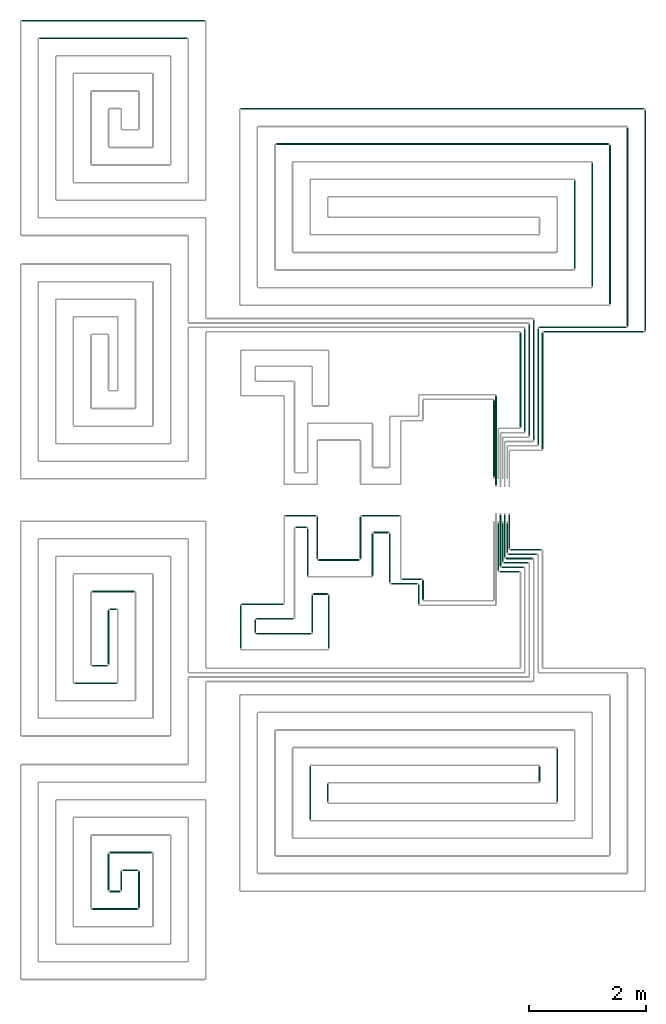
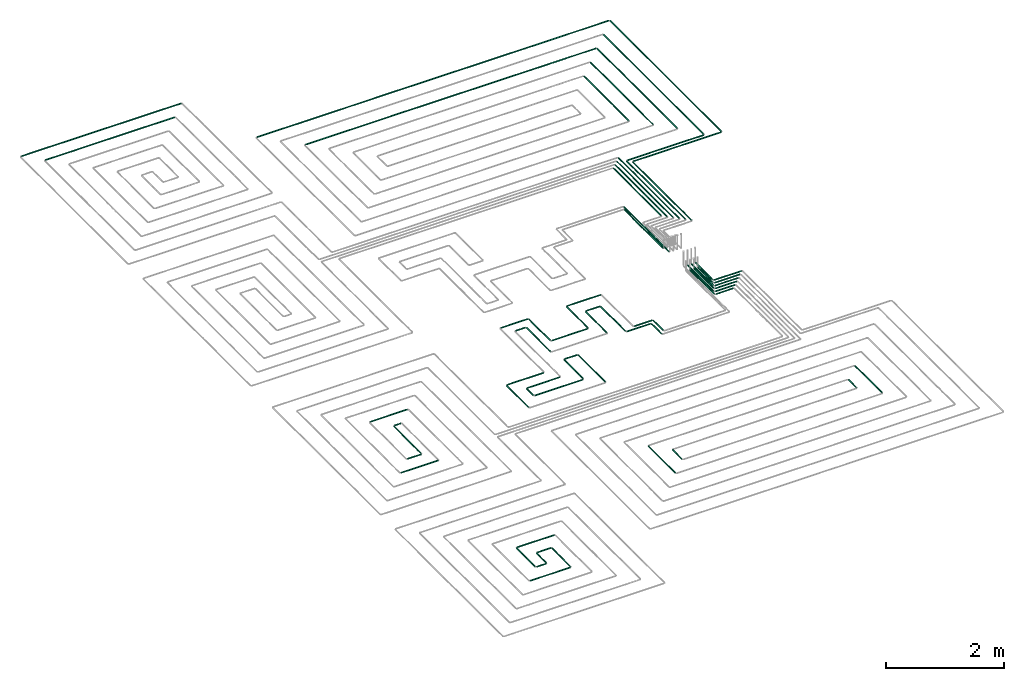
# One storey, part 3 of 12: 69 flow segments.
"""IFC2X3 building model written with IfcOpenShell, lengths in millimetres."""

from ifc_helpers import new_model, entity, si_unit, converted_unit, derived_unit, direction, frame, frame_2d, origin, origin_2d_with_axis, place, context, subcontext, project, spatial, circle, extrude, type_object, element, save


model = new_model("IFC2X3")

# Units and contexts
model_context = context("Model", 3, precision=0.01, world=origin(), true_north=direction((6.12303176911189e-17, 1.0)))
body_context = subcontext(model_context, "Body", "Model", "MODEL_VIEW")
ifc_project = project(units=[si_unit("LENGTHUNIT", "METRE", prefix="MILLI"), si_unit("AREAUNIT", "SQUARE_METRE"), si_unit("VOLUMEUNIT", "CUBIC_METRE"), converted_unit("PLANEANGLEUNIT", "DEGREE", entity("IfcRatioMeasure", 0.0174532925199433), si_unit("PLANEANGLEUNIT", "RADIAN"), dimensions=[0, 0, 0, 0, 0, 0, 0]), si_unit("MASSUNIT", "GRAM", prefix="KILO"), derived_unit("MASSDENSITYUNIT", [(si_unit("MASSUNIT", "GRAM", prefix="KILO"), 1), (si_unit("LENGTHUNIT", "METRE"), -3)]), si_unit("TIMEUNIT", "SECOND"), si_unit("FREQUENCYUNIT", "HERTZ"), si_unit("THERMODYNAMICTEMPERATUREUNIT", "DEGREE_CELSIUS"), derived_unit("THERMALTRANSMITTANCEUNIT", [(si_unit("MASSUNIT", "GRAM", prefix="KILO"), 1), (si_unit("THERMODYNAMICTEMPERATUREUNIT", "KELVIN"), -1), (si_unit("TIMEUNIT", "SECOND"), -3)]), derived_unit("VOLUMETRICFLOWRATEUNIT", [(si_unit("LENGTHUNIT", "METRE"), 3), (si_unit("TIMEUNIT", "SECOND"), -1)]), si_unit("ELECTRICCURRENTUNIT", "AMPERE"), si_unit("ELECTRICVOLTAGEUNIT", "VOLT"), si_unit("POWERUNIT", "WATT"), si_unit("FORCEUNIT", "NEWTON", prefix="KILO"), si_unit("ILLUMINANCEUNIT", "LUX"), si_unit("LUMINOUSFLUXUNIT", "LUMEN"), si_unit("LUMINOUSINTENSITYUNIT", "CANDELA"), derived_unit("USERDEFINED", [(si_unit("MASSUNIT", "GRAM", prefix="KILO"), -1), (si_unit("LENGTHUNIT", "METRE"), -2), (si_unit("TIMEUNIT", "SECOND"), 3), (si_unit("LUMINOUSFLUXUNIT", "LUMEN"), 1)]), derived_unit("LINEARVELOCITYUNIT", [(si_unit("LENGTHUNIT", "METRE"), 1), (si_unit("TIMEUNIT", "SECOND"), -1)]), si_unit("PRESSUREUNIT", "PASCAL"), derived_unit("USERDEFINED", [(si_unit("LENGTHUNIT", "METRE"), -2), (si_unit("MASSUNIT", "GRAM", prefix="KILO"), 1), (si_unit("TIMEUNIT", "SECOND"), -2)])], contexts=[model_context])

# Site, building, storey
site_placement = place(None, origin())
site = spatial("IfcSite", under=ifc_project, at=site_placement, CompositionType="ELEMENT")
building_placement = place(site_placement, origin())
building = spatial("IfcBuilding", under=site, at=building_placement, CompositionType="ELEMENT")
storey_placement = place(building_placement, frame((0.0, 0.0, 8000.0)))
storey = spatial("IfcBuildingStorey", under=building, at=storey_placement, Name="02 Level", CompositionType="ELEMENT", Elevation=8000.0)

# Flow segments
pipe_segment_type = type_object("IfcPipeSegmentType", PredefinedType="NOTDEFINED")
flow_segment_1_placement = place(storey_placement, frame((24021.0090559391, -70269.05691443, -81.5952722359243)))
element("IfcFlowSegment", 1, at=flow_segment_1_placement, inside=storey, type_object=pipe_segment_type, context=body_context, shape_type="SweptSolid", body=[
    extrude(circle(Radius=10.0, at=frame_2d((8.66293703438714e-12, 0.0), x_axis=(1.0, 0.0))), frame((0.0, 11.5952722359136, 11.5952722359158), z_axis=(1.0, 0.0, 0.0), x_axis=(0.0, 1.0, 0.0)), (0.0, 0.0, 1.0), 450.721832403925),
])
flow_segment_2_placement = place(storey_placement, frame((18625.6253473194, -71966.1931086591, -81.5952722359225)))
element("IfcFlowSegment", 2, at=flow_segment_2_placement, inside=storey, type_object=pipe_segment_type, context=body_context, shape_type="SweptSolid", body=[
    extrude(circle(Radius=10.0, at=origin_2d_with_axis()), frame((0.0, 11.5952722359136, 11.5952722359158), z_axis=(1.0, 0.0, 0.0), x_axis=(0.0, 1.0, 0.0)), (0.0, 0.0, 1.0), 718.813282054726),
])
flow_segment_3_placement = place(storey_placement, frame((18925.6253473194, -70402.8348573758, -81.5952722359234)))
element("IfcFlowSegment", 3, at=flow_segment_3_placement, inside=storey, type_object=pipe_segment_type, context=body_context, shape_type="SweptSolid", body=[
    extrude(circle(Radius=10.0, at=origin_2d_with_axis()), frame((0.0, 11.5952722359136, 11.5952722359158), z_axis=(1.0, 0.0, 0.0), x_axis=(0.0, -1.0, 0.0)), (0.0, 0.0, 1.0), 718.813282054721),
])
flow_segment_4_placement = place(storey_placement, frame((19225.6253473194, -70702.8348573758, -81.5952722359225)))
element("IfcFlowSegment", 4, at=flow_segment_4_placement, inside=storey, type_object=pipe_segment_type, context=body_context, shape_type="SweptSolid", body=[
    extrude(circle(Radius=10.0, at=frame_2d((-8.66293703438714e-12, 0.0), x_axis=(1.0, 0.0))), frame((0.0, 11.5952722359136, 11.5952722359158), z_axis=(1.0, 0.0, 0.0), x_axis=(0.0, 1.0, 0.0)), (0.0, 0.0, 1.0), 118.813282054734),
])
flow_segment_5_placement = place(storey_placement, frame((19194.0300750835, -71634.5978364232, -81.5952722359234)))
element("IfcFlowSegment", 5, at=flow_segment_5_placement, inside=storey, type_object=pipe_segment_type, context=body_context, shape_type="SweptSolid", body=[
    extrude(circle(Radius=10.0, at=frame_2d((-2.16573425859679e-12, 0.0), x_axis=(1.0, 0.0))), frame((11.595272235918, 0.0, 11.5952722359158), z_axis=(0.0, 1.0, 0.0), x_axis=(-1.0, 0.0, 0.0)), (0.0, 0.0, 1.0), 923.358251283313),
])
flow_segment_6_placement = place(storey_placement, frame((18925.6253473194, -71666.1931086591, -81.5952722359252)))
element("IfcFlowSegment", 6, at=flow_segment_6_placement, inside=storey, type_object=pipe_segment_type, context=body_context, shape_type="SweptSolid", body=[
    extrude(circle(Radius=10.0, at=frame_2d((8.66293703438714e-12, 0.0), x_axis=(1.0, 0.0))), frame((0.0, 11.5952722359136, 11.5952722359158), z_axis=(1.0, 0.0, 0.0), x_axis=(0.0, 1.0, 0.0)), (0.0, 0.0, 1.0), 260.000000000012),
])
flow_segment_7_placement = place(storey_placement, frame((19712.8433571382, -75784.5978364232, -81.5952722359252)))
element("IfcFlowSegment", 7, at=flow_segment_7_placement, inside=storey, type_object=pipe_segment_type, context=body_context, shape_type="SweptSolid", body=[
    extrude(circle(Radius=10.0, at=frame_2d((-8.66293703438714e-12, 0.0), x_axis=(1.0, 0.0))), frame((11.5952722359266, 0.0, 11.5952722359158), z_axis=(0.0, 1.0, 0.0), x_axis=(-1.0, 0.0, 0.0)), (0.0, 0.0, 1.0), 623.358251283277),
])
flow_segment_8_placement = place(storey_placement, frame((19412.8433571382, -75484.5978364232, -81.595272235927)))
element("IfcFlowSegment", 8, at=flow_segment_8_placement, inside=storey, type_object=pipe_segment_type, context=body_context, shape_type="SweptSolid", body=[
    extrude(circle(Radius=10.0, at=frame_2d((6.49720277579036e-12, 0.0), x_axis=(1.0, 0.0))), frame((11.5952722359223, 0.0, 11.5952722359158), z_axis=(0.0, 1.0, 0.0), x_axis=(-1.0, 0.0, 0.0)), (0.0, 0.0, 1.0), 323.358251283363),
])
flow_segment_9_placement = place(storey_placement, frame((19194.0300750835, -75484.5978364232, -81.5952722359252)))
element("IfcFlowSegment", 9, at=flow_segment_9_placement, inside=storey, type_object=pipe_segment_type, context=body_context, shape_type="SweptSolid", body=[
    extrude(circle(Radius=10.0, at=frame_2d((-6.49720277579036e-12, 0.0), x_axis=(1.0, 0.0))), frame((11.5952722359223, 0.0, 11.5952722359158), z_axis=(0.0, 1.0, 0.0), x_axis=(-1.0, 0.0, 0.0)), (0.0, 0.0, 1.0), 623.358251283355),
])
flow_segment_10_placement = place(storey_placement, frame((19225.6253473194, -74852.8348573758, -81.5952722359198)))
element("IfcFlowSegment", 10, at=flow_segment_10_placement, inside=storey, type_object=pipe_segment_type, context=body_context, shape_type="SweptSolid", body=[
    extrude(circle(Radius=10.0, at=frame_2d((-2.59888111031614e-11, 0.0), x_axis=(1.0, 0.0))), frame((0.0, 11.5952722359396, 11.5952722359158), z_axis=(1.0, 0.0, 0.0), x_axis=(0.0, 1.0, 0.0)), (0.0, 0.0, 1.0), 718.813282054736),
])
flow_segment_11_placement = place(storey_placement, frame((18925.6253473194, -75816.1931086591, -81.5952722359243)))
element("IfcFlowSegment", 11, at=flow_segment_11_placement, inside=storey, type_object=pipe_segment_type, context=body_context, shape_type="SweptSolid", body=[
    extrude(circle(Radius=10.0, at=frame_2d((3.46517481375486e-11, 0.0), x_axis=(1.0, 0.0))), frame((0.0, 11.595272235931, 11.5952722359158), z_axis=(1.0, 0.0, 0.0), x_axis=(0.0, 1.0, 0.0)), (0.0, 0.0, 1.0), 778.813282054757),
])
flow_segment_12_placement = place(storey_placement, frame((19225.6253473194, -75516.1931086591, -81.5952722359252)))
element("IfcFlowSegment", 12, at=flow_segment_12_placement, inside=storey, type_object=pipe_segment_type, context=body_context, shape_type="SweptSolid", body=[
    extrude(circle(Radius=10.0, at=origin_2d_with_axis()), frame((0.0, 11.5952722359136, 11.5952722359158), z_axis=(1.0, 0.0, 0.0), x_axis=(0.0, 1.0, 0.0)), (0.0, 0.0, 1.0), 178.813282054764),
])
flow_segment_13_placement = place(storey_placement, frame((19444.4386293741, -75152.8348573758, -81.5952722359243)))
element("IfcFlowSegment", 13, at=flow_segment_13_placement, inside=storey, type_object=pipe_segment_type, context=body_context, shape_type="SweptSolid", body=[
    extrude(circle(Radius=10.0, at=frame_2d((-8.66293703438714e-12, 0.0), x_axis=(1.0, 0.0))), frame((0.0, 11.595272235931, 11.5952722359158), z_axis=(1.0, 0.0, 0.0), x_axis=(0.0, 1.0, 0.0)), (0.0, 0.0, 1.0), 260.000000000017),
])
flow_segment_14_placement = place(storey_placement, frame((26841.5018091839, -73979.8436457933, -81.5952722359198)))
element("IfcFlowSegment", 14, at=flow_segment_14_placement, inside=storey, type_object=pipe_segment_type, context=body_context, shape_type="SweptSolid", body=[
    extrude(circle(Radius=10.0, at=frame_2d((-8.66293703438714e-12, 0.0), x_axis=(1.0, 0.0))), frame((11.5952722359266, 0.0, 11.5952722359158), z_axis=(0.0, 1.0, 0.0), x_axis=(-1.0, 0.0, 0.0)), (0.0, 0.0, 1.0), 907.858932130948),
])
flow_segment_15_placement = place(storey_placement, frame((22930.6562350406, -73979.8436457933, -81.5952722359307)))
element("IfcFlowSegment", 15, at=flow_segment_15_placement, inside=storey, type_object=pipe_segment_type, context=body_context, shape_type="SweptSolid", body=[
    extrude(circle(Radius=10.0, at=frame_2d((-4.33146851719357e-12, 0.0), x_axis=(1.0, 0.0))), frame((11.5952722359223, 0.0, 11.5952722359158), z_axis=(0.0, 1.0, 0.0), x_axis=(-1.0, 0.0, 0.0)), (0.0, 0.0, 1.0), 307.858932131015),
])
flow_segment_16_placement = place(storey_placement, frame((22630.6562350406, -74279.8436457932, -81.5952722359316)))
element("IfcFlowSegment", 16, at=flow_segment_16_placement, inside=storey, type_object=pipe_segment_type, context=body_context, shape_type="SweptSolid", body=[
    extrude(circle(Radius=10.0, at=frame_2d((-1.29944055515807e-11, 0.0), x_axis=(1.0, 0.0))), frame((11.595272235931, 0.0, 11.5952722359158), z_axis=(0.0, 1.0, 0.0), x_axis=(-1.0, 0.0, 0.0)), (0.0, 0.0, 1.0), 907.858932131),
])
flow_segment_17_placement = place(storey_placement, frame((26541.5018091839, -73631.9847136623, -81.5952722359252)))
element("IfcFlowSegment", 17, at=flow_segment_17_placement, inside=storey, type_object=pipe_segment_type, context=body_context, shape_type="SweptSolid", body=[
    extrude(circle(Radius=10.0, at=frame_2d((-4.33146851719357e-12, 0.0), x_axis=(1.0, 0.0))), frame((11.5952722359223, 0.0, 11.5952722359158), z_axis=(0.0, 1.0, 0.0), x_axis=(-1.0, 0.0, 0.0)), (0.0, 0.0, 1.0), 260.000000000019),
])
flow_segment_18_placement = place(storey_placement, frame((23989.4137837031, -70237.4616421941, -81.5952722359198)))
element("IfcFlowSegment", 18, at=flow_segment_18_placement, inside=storey, type_object=pipe_segment_type, context=body_context, shape_type="SweptSolid", body=[
    extrude(circle(Radius=10.0, at=frame_2d((-3.0320279620355e-11, 0.0), x_axis=(1.0, 0.0))), frame((11.5952722359439, 0.0, 11.5952722359158), z_axis=(0.0, 1.0, 0.0), x_axis=(-1.0, 0.0, 0.0)), (0.0, 0.0, 1.0), 831.830711127864),
])
flow_segment_19_placement = place(storey_placement, frame((22221.748982204, -69109.6350508284, -81.5952722359316)))
element("IfcFlowSegment", 19, at=flow_segment_19_placement, inside=storey, type_object=pipe_segment_type, context=body_context, shape_type="SweptSolid", body=[
    extrude(circle(Radius=10.0, at=frame_2d((-8.66293703438714e-12, 0.0), x_axis=(1.0, 0.0))), frame((0.0, 11.5952722359223, 11.5952722359158), z_axis=(1.0, 0.0, 0.0), x_axis=(0.0, 1.0, 0.0)), (0.0, 0.0, 1.0), 520.399525361204),
])
flow_segment_20_placement = place(storey_placement, frame((22396.748982204, -69309.6350508284, -81.5952722359225)))
element("IfcFlowSegment", 20, at=flow_segment_20_placement, inside=storey, type_object=pipe_segment_type, context=body_context, shape_type="SweptSolid", body=[
    extrude(circle(Radius=10.0, at=origin_2d_with_axis()), frame((0.0, 11.5952722359136, 11.5952722359158), z_axis=(1.0, 0.0, 0.0), x_axis=(0.0, 1.0, 0.0)), (0.0, 0.0, 1.0), 185.39952536122),
])
flow_segment_21_placement = place(storey_placement, frame((21695.3876311493, -71092.3249584181, -81.5952722359252)))
element("IfcFlowSegment", 21, at=flow_segment_21_placement, inside=storey, type_object=pipe_segment_type, context=body_context, shape_type="SweptSolid", body=[
    extrude(circle(Radius=10.0, at=origin_2d_with_axis()), frame((11.595272235918, 0.0, 11.5952722359158), z_axis=(0.0, 1.0, 0.0), x_axis=(-1.0, 0.0, 0.0)), (0.0, 0.0, 1.0), 216.085373278228),
])
flow_segment_22_placement = place(storey_placement, frame((21445.3876311493, -71362.3249584181, -81.5952722359252)))
element("IfcFlowSegment", 22, at=flow_segment_22_placement, inside=storey, type_object=pipe_segment_type, context=body_context, shape_type="SweptSolid", body=[
    extrude(circle(Radius=10.0, at=frame_2d((-1.73258740687743e-11, 0.0), x_axis=(1.0, 0.0))), frame((11.5952722359266, 0.0, 11.5952722359158), z_axis=(0.0, 1.0, 0.0), x_axis=(-1.0, 0.0, 0.0)), (0.0, 0.0, 1.0), 736.085373278231),
])
flow_segment_23_placement = place(storey_placement, frame((21726.9829033853, -71123.9202306541, -81.595272235927)))
element("IfcFlowSegment", 23, at=flow_segment_23_placement, inside=storey, type_object=pipe_segment_type, context=body_context, shape_type="SweptSolid", body=[
    extrude(circle(Radius=10.0, at=frame_2d((-8.66293703438714e-12, 0.0), x_axis=(1.0, 0.0))), frame((0.0, 11.5952722359136, 11.5952722359158), z_axis=(1.0, 0.0, 0.0), x_axis=(0.0, 1.0, 0.0)), (0.0, 0.0, 1.0), 931.77751147485),
])
flow_segment_24_placement = place(storey_placement, frame((21476.9829033853, -70617.8348573758, -81.5952722359243)))
element("IfcFlowSegment", 24, at=flow_segment_24_placement, inside=storey, type_object=pipe_segment_type, context=body_context, shape_type="SweptSolid", body=[
    extrude(circle(Radius=10.0, at=frame_2d((-8.66293703438714e-12, 0.0), x_axis=(1.0, 0.0))), frame((0.0, 11.5952722359223, 11.5952722359158), z_axis=(1.0, 0.0, 0.0), x_axis=(0.0, 1.0, 0.0)), (0.0, 0.0, 1.0), 704.766078818666),
])
flow_segment_25_placement = place(storey_placement, frame((21726.9829033853, -70867.8348573759, -81.5952722359225)))
element("IfcFlowSegment", 25, at=flow_segment_25_placement, inside=storey, type_object=pipe_segment_type, context=body_context, shape_type="SweptSolid", body=[
    extrude(circle(Radius=10.0, at=frame_2d((-8.66293703438714e-12, 0.0), x_axis=(1.0, 0.0))), frame((0.0, 11.595272235931, 11.5952722359158), z_axis=(1.0, 0.0, 0.0), x_axis=(0.0, 1.0, 0.0)), (0.0, 0.0, 1.0), 629.766078818679),
])
flow_segment_26_placement = place(storey_placement, frame((22667.1651426242, -71092.3249584181, -81.5952722359316)))
element("IfcFlowSegment", 26, at=flow_segment_26_placement, inside=storey, type_object=pipe_segment_type, context=body_context, shape_type="SweptSolid", body=[
    extrude(circle(Radius=10.0, at=frame_2d((-4.33146851719357e-12, 0.0), x_axis=(1.0, 0.0))), frame((11.595272235918, 0.0, 11.5952722359158), z_axis=(0.0, 1.0, 0.0), x_axis=(-1.0, 0.0, 0.0)), (0.0, 0.0, 1.0), 638.585373278218),
])
flow_segment_27_placement = place(storey_placement, frame((22947.1651426242, -71362.3249584182, -81.5952722359289)))
element("IfcFlowSegment", 27, at=flow_segment_27_placement, inside=storey, type_object=pipe_segment_type, context=body_context, shape_type="SweptSolid", body=[
    extrude(circle(Radius=10.0, at=frame_2d((-4.33146851719357e-12, 0.0), x_axis=(1.0, 0.0))), frame((11.5952722359223, 0.0, 11.5952722359158), z_axis=(0.0, 1.0, 0.0), x_axis=(-1.0, 0.0, 0.0)), (0.0, 0.0, 1.0), 908.585373278235),
])
flow_segment_28_placement = place(storey_placement, frame((22698.7604148601, -70445.3348573758, -81.5952722359289)))
element("IfcFlowSegment", 28, at=flow_segment_28_placement, inside=storey, type_object=pipe_segment_type, context=body_context, shape_type="SweptSolid", body=[
    extrude(circle(Radius=10.0, at=origin_2d_with_axis()), frame((0.0, 11.5952722359136, 11.5952722359158), z_axis=(1.0, 0.0, 0.0), x_axis=(0.0, 1.0, 0.0)), (0.0, 0.0, 1.0), 239.999999999976),
])
flow_segment_29_placement = place(storey_placement, frame((25981.0369719708, -69840.3348573759, -81.5952722359298)))
element("IfcFlowSegment", 29, at=flow_segment_29_placement, inside=storey, type_object=pipe_segment_type, context=body_context, shape_type="SweptSolid", body=[
    extrude(circle(Radius=10.0, at=origin_2d_with_axis()), frame((0.0, 11.5952722359136, 11.5952722359158), z_axis=(1.0, 0.0, 0.0), x_axis=(0.0, -1.0, 0.0)), (0.0, 0.0, 1.0), 452.648577476757),
])
flow_segment_30_placement = place(storey_placement, frame((25946.0369719708, -69915.3348573758, -81.5952722359307)))
element("IfcFlowSegment", 30, at=flow_segment_30_placement, inside=storey, type_object=pipe_segment_type, context=body_context, shape_type="SweptSolid", body=[
    extrude(circle(Radius=10.0, at=origin_2d_with_axis()), frame((0.0, 11.5952722359223, 11.5952722359158), z_axis=(1.0, 0.0, 0.0), x_axis=(0.0, -1.0, 0.0)), (0.0, 0.0, 1.0), 412.648577476762),
])
flow_segment_31_placement = place(storey_placement, frame((25906.0369719708, -69990.3348573758, -81.5952722359298)))
element("IfcFlowSegment", 31, at=flow_segment_31_placement, inside=storey, type_object=pipe_segment_type, context=body_context, shape_type="SweptSolid", body=[
    extrude(circle(Radius=10.0, at=origin_2d_with_axis()), frame((0.0, 11.5952722359223, 11.5952722359158), z_axis=(1.0, 0.0, 0.0), x_axis=(0.0, -1.0, 0.0)), (0.0, 0.0, 1.0), 377.648577476765),
])
flow_segment_32_placement = place(storey_placement, frame((25871.0369719708, -70065.3348573758, -81.5952722359289)))
element("IfcFlowSegment", 32, at=flow_segment_32_placement, inside=storey, type_object=pipe_segment_type, context=body_context, shape_type="SweptSolid", body=[
    extrude(circle(Radius=10.0, at=origin_2d_with_axis()), frame((0.0, 11.5952722359136, 11.5952722359158), z_axis=(1.0, 0.0, 0.0), x_axis=(0.0, -1.0, 0.0)), (0.0, 0.0, 1.0), 337.64857747677),
])
flow_segment_33_placement = place(storey_placement, frame((26056.0369719708, -69690.3348573759, -81.5952722359316)))
element("IfcFlowSegment", 33, at=flow_segment_33_placement, inside=storey, type_object=pipe_segment_type, context=body_context, shape_type="SweptSolid", body=[
    extrude(circle(Radius=10.0, at=origin_2d_with_axis()), frame((0.0, 11.5952722359136, 11.5952722359158), z_axis=(1.0, 0.0, 0.0), x_axis=(0.0, -1.0, 0.0)), (0.0, 0.0, 1.0), 527.648577476736),
])
flow_segment_34_placement = place(storey_placement, frame((26021.0369719708, -69765.3348573759, -81.5952722359298)))
element("IfcFlowSegment", 34, at=flow_segment_34_placement, inside=storey, type_object=pipe_segment_type, context=body_context, shape_type="SweptSolid", body=[
    extrude(circle(Radius=10.0, at=origin_2d_with_axis()), frame((0.0, 11.5952722359136, 11.5952722359158), z_axis=(1.0, 0.0, 0.0), x_axis=(0.0, -1.0, 0.0)), (0.0, 0.0, 1.0), 487.648577476745),
])
flow_segment_35_placement = place(storey_placement, frame((25839.4416997349, -70033.7395851399, -81.5952722359289)))
element("IfcFlowSegment", 35, at=flow_segment_35_placement, inside=storey, type_object=pipe_segment_type, context=body_context, shape_type="SweptSolid", body=[
    extrude(circle(Radius=10.0, at=origin_2d_with_axis()), frame((11.595272235918, 0.0, 11.5952722359158), z_axis=(0.0, 1.0, 0.0), x_axis=(1.0, 0.0, 0.0)), (0.0, 0.0, 1.0), 807.49999999999),
])
flow_segment_36_placement = place(storey_placement, frame((25914.4416997349, -69883.7395851399, -81.5952722359307)))
element("IfcFlowSegment", 36, at=flow_segment_36_placement, inside=storey, type_object=pipe_segment_type, context=body_context, shape_type="SweptSolid", body=[
    extrude(circle(Radius=10.0, at=origin_2d_with_axis()), frame((11.595272235918, 0.0, 11.5952722359158), z_axis=(0.0, 1.0, 0.0), x_axis=(1.0, 0.0, 0.0)), (0.0, 0.0, 1.0), 657.499999999989),
])
flow_segment_37_placement = place(storey_placement, frame((25989.4416997349, -69733.7395851399, -81.5952722359307)))
element("IfcFlowSegment", 37, at=flow_segment_37_placement, inside=storey, type_object=pipe_segment_type, context=body_context, shape_type="SweptSolid", body=[
    extrude(circle(Radius=10.0, at=origin_2d_with_axis()), frame((11.595272235918, 0.0, 11.5952722359158), z_axis=(0.0, 1.0, 0.0), x_axis=(1.0, 0.0, 0.0)), (0.0, 0.0, 1.0), 507.500000000015),
])
flow_segment_38_placement = place(storey_placement, frame((26024.4416997349, -69658.7395851399, -81.5952722359307)))
element("IfcFlowSegment", 38, at=flow_segment_38_placement, inside=storey, type_object=pipe_segment_type, context=body_context, shape_type="SweptSolid", body=[
    extrude(circle(Radius=10.0, at=origin_2d_with_axis()), frame((11.595272235918, 0.0, 11.5952722359158), z_axis=(0.0, 1.0, 0.0), x_axis=(1.0, 0.0, 0.0)), (0.0, 0.0, 1.0), 572.499999999991),
])
flow_segment_39_placement = place(storey_placement, frame((25949.4416997349, -69808.7395851399, -81.5952722359289)))
element("IfcFlowSegment", 39, at=flow_segment_39_placement, inside=storey, type_object=pipe_segment_type, context=body_context, shape_type="SweptSolid", body=[
    extrude(circle(Radius=10.0, at=origin_2d_with_axis()), frame((11.595272235918, 0.0, 11.5952722359158), z_axis=(0.0, 1.0, 0.0), x_axis=(1.0, 0.0, 0.0)), (0.0, 0.0, 1.0), 722.499999999974),
])
flow_segment_40_placement = place(storey_placement, frame((25874.4416997349, -69958.7395851399, -81.5952722359307)))
element("IfcFlowSegment", 40, at=flow_segment_40_placement, inside=storey, type_object=pipe_segment_type, context=body_context, shape_type="SweptSolid", body=[
    extrude(circle(Radius=10.0, at=origin_2d_with_axis()), frame((11.595272235918, 0.0, 11.5952722359158), z_axis=(0.0, 1.0, 0.0), x_axis=(1.0, 0.0, 0.0)), (0.0, 0.0, 1.0), 872.499999999958),
])
flow_segment_41_placement = place(storey_placement, frame((24206.0090559391, -70194.0569144301, -81.5952722359289)))
element("IfcFlowSegment", 41, at=flow_segment_41_placement, inside=storey, type_object=pipe_segment_type, context=body_context, shape_type="SweptSolid", body=[
    extrude(circle(Radius=10.0, at=frame_2d((1.73258740687743e-11, 0.0), x_axis=(1.0, 0.0))), frame((0.0, 11.595272235931, 11.5952722359158), z_axis=(1.0, 0.0, 0.0), x_axis=(0.0, 1.0, 0.0)), (0.0, 0.0, 1.0), 340.721832403933),
])
flow_segment_42_placement = place(storey_placement, frame((24480.1356161071, -70606.3143518619, -81.5952722359243)))
element("IfcFlowSegment", 42, at=flow_segment_42_placement, inside=storey, type_object=pipe_segment_type, context=body_context, shape_type="SweptSolid", body=[
    extrude(circle(Radius=10.0, at=frame_2d((-8.66293703438714e-12, 0.0), x_axis=(1.0, 0.0))), frame((11.595272235918, 0.0, 11.5952722359158), z_axis=(0.0, 1.0, 0.0), x_axis=(-1.0, 0.0, 0.0)), (0.0, 0.0, 1.0), 328.852709667764),
])
flow_segment_43_placement = place(storey_placement, frame((24555.1356161071, -70531.3143518619, -81.595272235927)))
element("IfcFlowSegment", 43, at=flow_segment_43_placement, inside=storey, type_object=pipe_segment_type, context=body_context, shape_type="SweptSolid", body=[
    extrude(circle(Radius=10.0, at=origin_2d_with_axis()), frame((11.595272235918, 0.0, 11.5952722359158), z_axis=(0.0, 1.0, 0.0), x_axis=(1.0, 0.0, 0.0)), (0.0, 0.0, 1.0), 328.852709667773),
])
flow_segment_44_placement = place(storey_placement, frame((22590.5532353292, -70121.2395851399, -81.5952722359225)))
element("IfcFlowSegment", 44, at=flow_segment_44_placement, inside=storey, type_object=pipe_segment_type, context=body_context, shape_type="SweptSolid", body=[
    extrude(circle(Radius=10.0, at=frame_2d((-2.16573425859679e-11, 0.0), x_axis=(1.0, 0.0))), frame((11.5952722359439, 0.0, 11.5952722359158), z_axis=(0.0, 1.0, 0.0), x_axis=(-1.0, 0.0, 0.0)), (0.0, 0.0, 1.0), 803.199806547433),
])
flow_segment_45_placement = place(storey_placement, frame((22750.5532353292, -69833.6484326662, -81.5952722359316)))
element("IfcFlowSegment", 45, at=flow_segment_45_placement, inside=storey, type_object=pipe_segment_type, context=body_context, shape_type="SweptSolid", body=[
    extrude(circle(Radius=10.0, at=frame_2d((-2.16573425859679e-11, 0.0), x_axis=(1.0, 0.0))), frame((11.5952722359396, 0.0, 11.5952722359158), z_axis=(0.0, 1.0, 0.0), x_axis=(-1.0, 0.0, 0.0)), (0.0, 0.0, 1.0), 715.608654073691),
])
flow_segment_46_placement = place(storey_placement, frame((23519.956152799, -69109.6350508284, -81.5952722359298)))
element("IfcFlowSegment", 46, at=flow_segment_46_placement, inside=storey, type_object=pipe_segment_type, context=body_context, shape_type="SweptSolid", body=[
    extrude(circle(Radius=10.0, at=origin_2d_with_axis()), frame((0.0, 11.5952722359396, 11.5952722359158), z_axis=(1.0, 0.0, 0.0), x_axis=(0.0, -1.0, 0.0)), (0.0, 0.0, 1.0), 646.052903140118),
])
flow_segment_47_placement = place(storey_placement, frame((23724.956152799, -69397.2262033022, -81.5952722359225)))
element("IfcFlowSegment", 47, at=flow_segment_47_placement, inside=storey, type_object=pipe_segment_type, context=body_context, shape_type="SweptSolid", body=[
    extrude(circle(Radius=10.0, at=origin_2d_with_axis()), frame((0.0, 11.595272235931, 11.5952722359158), z_axis=(1.0, 0.0, 0.0), x_axis=(0.0, -1.0, 0.0)), (0.0, 0.0, 1.0), 256.052903140129),
])
for number, where in (
    (48, (23488.3608805631, -69833.6484326662, -81.5952722359298)),
    (49, (23693.360880563, -70121.2395851399, -81.5952722359225)),
):
    element("IfcFlowSegment", number, at=place(storey_placement, frame(where)), inside=storey, type_object=pipe_segment_type, context=body_context, shape_type="SweptSolid", body=[
        extrude(circle(Radius=10.0, at=frame_2d((-1.29944055515807e-11, 0.0), x_axis=(1.0, 0.0))), frame((11.595272235931, 0.0, 11.5952722359158), z_axis=(0.0, 1.0, 0.0), x_axis=(-1.0, 0.0, 0.0)), (0.0, 0.0, 1.0), 715.608654073717),
    ])
flow_segment_48_placement = place(storey_placement, frame((22782.1485075651, -69865.2437049021, -81.5952722359289)))
element("IfcFlowSegment", 50, at=flow_segment_48_placement, inside=storey, type_object=pipe_segment_type, context=body_context, shape_type="SweptSolid", body=[
    extrude(circle(Radius=10.0, at=frame_2d((-8.66293703438714e-12, 0.0), x_axis=(1.0, 0.0))), frame((0.0, 11.5952722359223, 11.5952722359158), z_axis=(1.0, 0.0, 0.0), x_axis=(0.0, 1.0, 0.0)), (0.0, 0.0, 1.0), 697.807645233866),
])
flow_segment_49_placement = place(storey_placement, frame((18025.6253473194, -60969.4766060926, -81.5952722359179)))
element("IfcFlowSegment", 51, at=flow_segment_49_placement, inside=storey, type_object=pipe_segment_type, context=body_context, shape_type="SweptSolid", body=[
    extrude(circle(Radius=10.0, at=frame_2d((-8.66293703438714e-12, 0.0), x_axis=(1.0, 0.0))), frame((0.0, 11.5952722359136, 11.5952722359158), z_axis=(1.0, 0.0, 0.0), x_axis=(0.0, 1.0, 0.0)), (0.0, 0.0, 1.0), 2518.8132820547),
])
flow_segment_50_placement = place(storey_placement, frame((17725.6253473194, -60669.4766060926, -81.5952722359161)))
element("IfcFlowSegment", 52, at=flow_segment_50_placement, inside=storey, type_object=pipe_segment_type, context=body_context, shape_type="SweptSolid", body=[
    extrude(circle(Radius=10.0, at=frame_2d((8.66293703438714e-12, 0.0), x_axis=(1.0, 0.0))), frame((0.0, 11.5952722359136, 11.5952722359158), z_axis=(1.0, 0.0, 0.0), x_axis=(0.0, 1.0, 0.0)), (0.0, 0.0, 1.0), 3118.81328205468),
])
flow_segment_51_placement = place(storey_placement, frame((26623.6855494475, -65974.0247077234, -81.5952722359161)))
element("IfcFlowSegment", 53, at=flow_segment_51_placement, inside=storey, type_object=pipe_segment_type, context=body_context, shape_type="SweptSolid", body=[
    extrude(circle(Radius=10.0, at=origin_2d_with_axis()), frame((0.0, 11.5952722359483, 11.5952722359158), z_axis=(1.0, 0.0, 0.0), x_axis=(0.0, -1.0, 0.0)), (0.0, 0.0, 1.0), 1709.41153197237),
])
flow_segment_52_placement = place(storey_placement, frame((26548.6855494475, -65899.0247077234, -81.5952722359143)))
element("IfcFlowSegment", 54, at=flow_segment_52_placement, inside=storey, type_object=pipe_segment_type, context=body_context, shape_type="SweptSolid", body=[
    extrude(circle(Radius=10.0, at=origin_2d_with_axis()), frame((0.0, 11.5952722359483, 11.5952722359158), z_axis=(1.0, 0.0, 0.0), x_axis=(0.0, -1.0, 0.0)), (0.0, 0.0, 1.0), 1484.41153197236),
])
flow_segment_53_placement = place(storey_placement, frame((28341.5018091839, -65942.4294354875, -81.5952722359161)))
element("IfcFlowSegment", 55, at=flow_segment_53_placement, inside=storey, type_object=pipe_segment_type, context=body_context, shape_type="SweptSolid", body=[
    extrude(circle(Radius=10.0, at=frame_2d((2.59888111031614e-11, 0.0), x_axis=(1.0, 0.0))), frame((11.5952722359439, 0.0, 11.5952722359158), z_axis=(0.0, 1.0, 0.0), x_axis=(-1.0, 0.0, 0.0)), (0.0, 0.0, 1.0), 3759.79391100087),
])
flow_segment_54_placement = place(storey_placement, frame((28041.5018091839, -65867.4294354875, -81.5952722359179)))
element("IfcFlowSegment", 56, at=flow_segment_54_placement, inside=storey, type_object=pipe_segment_type, context=body_context, shape_type="SweptSolid", body=[
    extrude(circle(Radius=10.0, at=origin_2d_with_axis()), frame((11.5952722359613, 0.0, 11.5952722359158), z_axis=(0.0, 1.0, 0.0), x_axis=(1.0, 0.0, 0.0)), (0.0, 0.0, 1.0), 3384.79391100087),
])
flow_segment_55_placement = place(storey_placement, frame((27741.5018091839, -65490.4944566175, -81.595272235917)))
element("IfcFlowSegment", 57, at=flow_segment_55_placement, inside=storey, type_object=pipe_segment_type, context=body_context, shape_type="SweptSolid", body=[
    extrude(circle(Radius=10.0, at=frame_2d((2.16573425859679e-11, 0.0), x_axis=(1.0, 0.0))), frame((11.5952722359439, 0.0, 11.5952722359158), z_axis=(0.0, 1.0, 0.0), x_axis=(-1.0, 0.0, 0.0)), (0.0, 0.0, 1.0), 2707.85893213088),
])
flow_segment_56_placement = place(storey_placement, frame((27441.501809184, -65190.4944566175, -81.5952722359161)))
element("IfcFlowSegment", 58, at=flow_segment_56_placement, inside=storey, type_object=pipe_segment_type, context=body_context, shape_type="SweptSolid", body=[
    extrude(circle(Radius=10.0, at=origin_2d_with_axis()), frame((11.5952722359439, 0.0, 11.5952722359158), z_axis=(0.0, 1.0, 0.0), x_axis=(1.0, 0.0, 0.0)), (0.0, 0.0, 1.0), 2107.85893213088),
])
flow_segment_57_placement = place(storey_placement, frame((21462.2515072766, -62174.2307967226, -81.5952722359143)))
element("IfcFlowSegment", 59, at=flow_segment_57_placement, inside=storey, type_object=pipe_segment_type, context=body_context, shape_type="SweptSolid", body=[
    extrude(circle(Radius=10.0, at=origin_2d_with_axis()), frame((0.0, 11.5952722359136, 11.5952722359158), z_axis=(1.0, 0.0, 0.0), x_axis=(0.0, 1.0, 0.0)), (0.0, 0.0, 1.0), 6870.84557414322),
])
flow_segment_58_placement = place(storey_placement, frame((22062.2515072766, -62774.2307967226, -81.5952722359289)))
element("IfcFlowSegment", 60, at=flow_segment_58_placement, inside=storey, type_object=pipe_segment_type, context=body_context, shape_type="SweptSolid", body=[
    extrude(circle(Radius=10.0, at=origin_2d_with_axis()), frame((0.0, 11.5952722359136, 11.5952722359158), z_axis=(1.0, 0.0, 0.0), x_axis=(0.0, -1.0, 0.0)), (0.0, 0.0, 1.0), 5670.84557414326),
])
flow_segment_59_placement = place(storey_placement, frame((27141.501809184, -64890.4944566176, -81.5952722359198)))
element("IfcFlowSegment", 61, at=flow_segment_59_placement, inside=storey, type_object=pipe_segment_type, context=body_context, shape_type="SweptSolid", body=[
    extrude(circle(Radius=10.0, at=frame_2d((8.66293703438714e-12, 0.0), x_axis=(1.0, 0.0))), frame((11.5952722359266, 0.0, 11.5952722359158), z_axis=(0.0, 1.0, 0.0), x_axis=(-1.0, 0.0, 0.0)), (0.0, 0.0, 1.0), 1507.85893213094),
])
flow_segment_60_placement = place(storey_placement, frame((26442.0902772116, -67813.73958514, -81.5952722359179)))
element("IfcFlowSegment", 62, at=flow_segment_60_placement, inside=storey, type_object=pipe_segment_type, context=body_context, shape_type="SweptSolid", body=[
    extrude(circle(Radius=10.0, at=origin_2d_with_axis()), frame((11.595272235918, 0.0, 11.5952722359158), z_axis=(0.0, 1.0, 0.0), x_axis=(1.0, 0.0, 0.0)), (0.0, 0.0, 1.0), 2056.31014965248),
])
flow_segment_61_placement = place(storey_placement, frame((26367.0902772116, -67738.73958514, -81.5952722359143)))
element("IfcFlowSegment", 63, at=flow_segment_61_placement, inside=storey, type_object=pipe_segment_type, context=body_context, shape_type="SweptSolid", body=[
    extrude(circle(Radius=10.0, at=frame_2d((-8.66293703438714e-12, 0.0), x_axis=(1.0, 0.0))), frame((11.5952722359266, 0.0, 11.5952722359158), z_axis=(0.0, 1.0, 0.0), x_axis=(-1.0, 0.0, 0.0)), (0.0, 0.0, 1.0), 1906.31014965249),
])
flow_segment_62_placement = place(storey_placement, frame((26292.0902772116, -67663.73958514, -81.5952722359143)))
element("IfcFlowSegment", 64, at=flow_segment_62_placement, inside=storey, type_object=pipe_segment_type, context=body_context, shape_type="SweptSolid", body=[
    extrude(circle(Radius=10.0, at=frame_2d((-4.33146851719357e-12, 0.0), x_axis=(1.0, 0.0))), frame((11.5952722359223, 0.0, 11.5952722359158), z_axis=(0.0, 1.0, 0.0), x_axis=(-1.0, 0.0, 0.0)), (0.0, 0.0, 1.0), 1756.31014965249),
])
flow_segment_63_placement = place(storey_placement, frame((26217.0902772116, -67588.73958514, -81.5952722359179)))
element("IfcFlowSegment", 65, at=flow_segment_63_placement, inside=storey, type_object=pipe_segment_type, context=body_context, shape_type="SweptSolid", body=[
    extrude(circle(Radius=10.0, at=origin_2d_with_axis()), frame((11.5952722359223, 0.0, 11.5952722359158), z_axis=(0.0, 1.0, 0.0), x_axis=(1.0, 0.0, 0.0)), (0.0, 0.0, 1.0), 1606.3101496525),
])
flow_segment_64_placement = place(storey_placement, frame((26592.0902772116, -67963.7395851399, -81.5952722359179)))
element("IfcFlowSegment", 66, at=flow_segment_64_placement, inside=storey, type_object=pipe_segment_type, context=body_context, shape_type="SweptSolid", body=[
    extrude(circle(Radius=10.0, at=frame_2d((-4.33146851719357e-12, 0.0), x_axis=(1.0, 0.0))), frame((11.5952722359223, 0.0, 11.5952722359158), z_axis=(0.0, 1.0, 0.0), x_axis=(1.0, 0.0, 0.0)), (0.0, 0.0, 1.0), 1981.31014965248),
])
flow_segment_65_placement = place(storey_placement, frame((26517.0902772116, -67888.73958514, -81.5952722359161)))
element("IfcFlowSegment", 67, at=flow_segment_65_placement, inside=storey, type_object=pipe_segment_type, context=body_context, shape_type="SweptSolid", body=[
    extrude(circle(Radius=10.0, at=frame_2d((-8.66293703438714e-12, 0.0), x_axis=(1.0, 0.0))), frame((11.5952722359266, 0.0, 11.5952722359158), z_axis=(0.0, 1.0, 0.0), x_axis=(-1.0, 0.0, 0.0)), (0.0, 0.0, 1.0), 1981.31014965249),
])
flow_segment_66_placement = place(storey_placement, frame((25764.4416997349, -68436.2395851399, -81.5952722359243)))
element("IfcFlowSegment", 68, at=flow_segment_66_placement, inside=storey, type_object=pipe_segment_type, context=body_context, shape_type="SweptSolid", body=[
    extrude(circle(Radius=10.0, at=origin_2d_with_axis()), frame((11.5952722359223, 0.0, 11.5952722359158), z_axis=(0.0, 1.0, 0.0), x_axis=(-1.0, 0.0, 0.0)), (0.0, 0.0, 1.0), 1305.07476672193),
])
flow_segment_67_placement = place(storey_placement, frame((25799.4416997349, -68576.2395851399, -81.5952722359289)))
element("IfcFlowSegment", 69, at=flow_segment_67_placement, inside=storey, type_object=pipe_segment_type, context=body_context, shape_type="SweptSolid", body=[
    extrude(circle(Radius=10.0, at=frame_2d((-4.33146851719357e-12, 0.0), x_axis=(1.0, 0.0))), frame((11.5952722359223, 0.0, 11.5952722359158), z_axis=(0.0, 1.0, 0.0), x_axis=(-1.0, 0.0, 0.0)), (0.0, 0.0, 1.0), 1520.07476672191),
])

save(model, "model.ifc")
